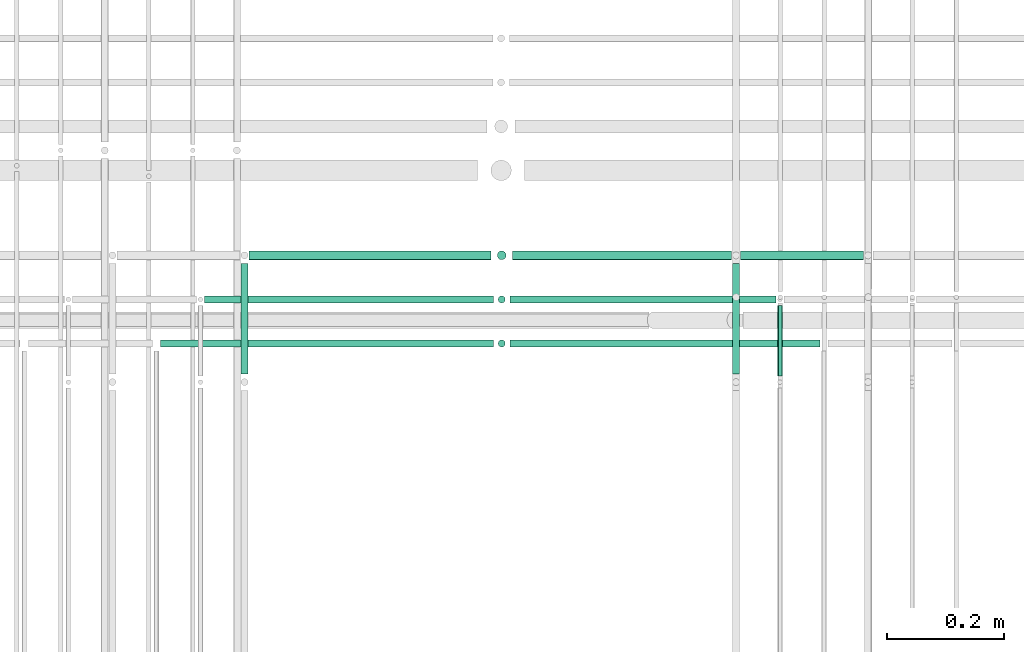
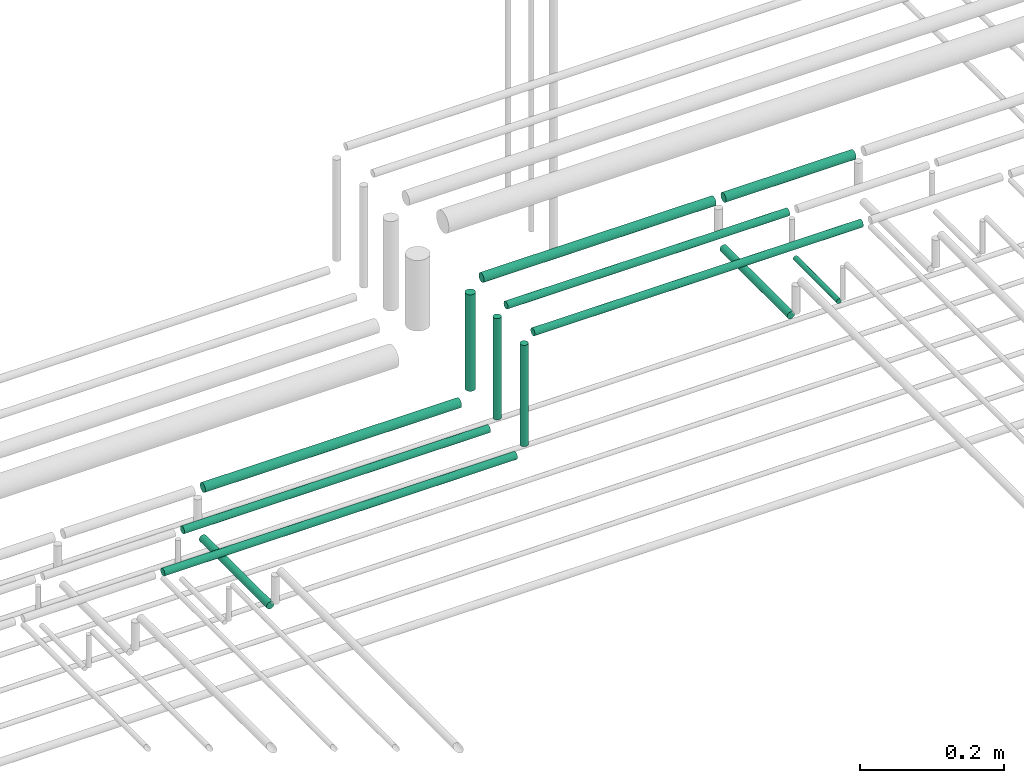
# One storey, part 152 of 331: 13 flow segments.
"""IFC2X3 building model written with IfcOpenShell, lengths in millimetres."""

from ifc_helpers import new_model, entity, si_unit, converted_unit, derived_unit, direction, frame, frame_2d, origin, origin_2d_with_axis, place, context, subcontext, project, spatial, circle, extrude, type_object, element, save


model = new_model("IFC2X3")

# Units and contexts
model_context = context("Model", 3, precision=0.01, world=origin(), true_north=direction((6.12303176911189e-17, 1.0)))
body_context = subcontext(model_context, "Body", "Model", "MODEL_VIEW")
ifc_project = project(units=[si_unit("LENGTHUNIT", "METRE", prefix="MILLI"), si_unit("AREAUNIT", "SQUARE_METRE"), si_unit("VOLUMEUNIT", "CUBIC_METRE"), converted_unit("PLANEANGLEUNIT", "DEGREE", entity("IfcRatioMeasure", 0.0174532925199433), si_unit("PLANEANGLEUNIT", "RADIAN"), dimensions=[0, 0, 0, 0, 0, 0, 0]), si_unit("MASSUNIT", "GRAM", prefix="KILO"), derived_unit("MASSDENSITYUNIT", [(si_unit("MASSUNIT", "GRAM", prefix="KILO"), 1), (si_unit("LENGTHUNIT", "METRE"), -3)]), derived_unit("MOMENTOFINERTIAUNIT", [(si_unit("LENGTHUNIT", "METRE"), 4)]), si_unit("TIMEUNIT", "SECOND"), si_unit("FREQUENCYUNIT", "HERTZ"), si_unit("THERMODYNAMICTEMPERATUREUNIT", "DEGREE_CELSIUS"), derived_unit("THERMALTRANSMITTANCEUNIT", [(si_unit("MASSUNIT", "GRAM", prefix="KILO"), 1), (si_unit("THERMODYNAMICTEMPERATUREUNIT", "KELVIN"), -1), (si_unit("TIMEUNIT", "SECOND"), -3)]), derived_unit("VOLUMETRICFLOWRATEUNIT", [(si_unit("LENGTHUNIT", "METRE"), 3), (si_unit("TIMEUNIT", "SECOND"), -1)]), derived_unit("MASSFLOWRATEUNIT", [(si_unit("MASSUNIT", "GRAM", prefix="KILO"), 1), (si_unit("TIMEUNIT", "SECOND"), -1)]), derived_unit("ROTATIONALFREQUENCYUNIT", [(si_unit("TIMEUNIT", "SECOND"), -1)]), si_unit("ELECTRICCURRENTUNIT", "AMPERE"), si_unit("ELECTRICVOLTAGEUNIT", "VOLT"), si_unit("POWERUNIT", "WATT"), si_unit("FORCEUNIT", "NEWTON", prefix="KILO"), si_unit("ILLUMINANCEUNIT", "LUX"), si_unit("LUMINOUSFLUXUNIT", "LUMEN"), si_unit("LUMINOUSINTENSITYUNIT", "CANDELA"), derived_unit("USERDEFINED", [(si_unit("MASSUNIT", "GRAM", prefix="KILO"), -1), (si_unit("LENGTHUNIT", "METRE"), -2), (si_unit("TIMEUNIT", "SECOND"), 3), (si_unit("LUMINOUSFLUXUNIT", "LUMEN"), 1)]), derived_unit("LINEARVELOCITYUNIT", [(si_unit("LENGTHUNIT", "METRE"), 1), (si_unit("TIMEUNIT", "SECOND"), -1)]), si_unit("PRESSUREUNIT", "PASCAL"), derived_unit("USERDEFINED", [(si_unit("LENGTHUNIT", "METRE"), -2), (si_unit("MASSUNIT", "GRAM", prefix="KILO"), 1), (si_unit("TIMEUNIT", "SECOND"), -2)]), derived_unit("LINEARFORCEUNIT", [(si_unit("MASSUNIT", "GRAM", prefix="KILO"), 1), (si_unit("LENGTHUNIT", "METRE"), 1), (si_unit("TIMEUNIT", "SECOND"), -2), (si_unit("LENGTHUNIT", "METRE"), -1)]), derived_unit("PLANARFORCEUNIT", [(si_unit("MASSUNIT", "GRAM", prefix="KILO"), 1), (si_unit("LENGTHUNIT", "METRE"), 1), (si_unit("TIMEUNIT", "SECOND"), -2), (si_unit("LENGTHUNIT", "METRE"), -2)])], contexts=[model_context])

# Site, building, storey
site_placement = place(None, frame((0.0, -0.00077364408347762, 0.0)))
site = spatial("IfcSite", under=ifc_project, at=site_placement, CompositionType="ELEMENT")
building_placement = place(site_placement, origin())
building = spatial("IfcBuilding", under=site, at=building_placement, CompositionType="ELEMENT")
storey_placement = place(building_placement, origin())
storey = spatial("IfcBuildingStorey", under=building, at=storey_placement, CompositionType="ELEMENT", Elevation=0.0)

# Flow segments
pipe_segment_type = type_object("IfcPipeSegmentType", PredefinedType="NOTDEFINED")
flow_segment_1_placement = place(storey_placement, frame((35465.5130615671, 8100.14924977613, 14669.4047277641)))
element("IfcFlowSegment", 1, at=flow_segment_1_placement, inside=storey, type_object=pipe_segment_type, context=body_context, shape_type="SweptSolid", body=[
    extrude(circle(Radius=4.0, at=origin_2d_with_axis()), frame((5.59527223591499, 0.0, 5.59527223591499), z_axis=(0.0, 1.0, 0.0), x_axis=(1.0, 0.0, 0.0)), (0.0, 0.0, 1.0), 120.860694073197),
])
flow_segment_2_placement = place(storey_placement, frame((35388.5130615671, 8104.14924977614, 14667.4047277641)))
element("IfcFlowSegment", 2, at=flow_segment_2_placement, inside=storey, type_object=pipe_segment_type, context=body_context, shape_type="SweptSolid", body=[
    extrude(circle(Radius=6.0, at=frame_2d((0.0, 2.16573425859679e-12), x_axis=(1.0, 0.0))), frame((7.59527223591454, 0.0, 7.59527223591887), z_axis=(0.0, 1.0, 0.0), x_axis=(1.0, 0.0, 0.0)), (0.0, 0.0, 1.0), 187.860694073183),
])
flow_segment_3_placement = place(storey_placement, frame((34551.5132627125, 8104.14924966515, 14467.404727873)))
element("IfcFlowSegment", 3, at=flow_segment_3_placement, inside=storey, type_object=pipe_segment_type, context=body_context, shape_type="SweptSolid", body=[
    extrude(circle(Radius=6.0, at=origin_2d_with_axis()), frame((7.59527223591454, 0.0, 7.5952722359167), z_axis=(0.0, 1.0, 0.0), x_axis=(1.0, 0.0, 0.0)), (0.0, 0.0, 1.0), 187.860694073193),
])
flow_segment_4_placement = place(storey_placement, frame((34416.1085349484, 8148.41467161337, 14542.404727764)))
element("IfcFlowSegment", 4, at=flow_segment_4_placement, inside=storey, type_object=pipe_segment_type, context=body_context, shape_type="SweptSolid", body=[
    extrude(circle(Radius=6.0, at=frame_2d((9.74580416368554e-12, 0.0), x_axis=(1.0, 0.0))), frame((0.0, 7.59527223592536, 7.5952722359167), z_axis=(1.0, 0.0, 0.0), x_axis=(0.0, 1.0, 0.0)), (0.0, 0.0, 1.0), 566.972016513596),
])
flow_segment_5_placement = place(storey_placement, frame((34491.1085388696, 8223.41467161341, 14542.4040101932)))
element("IfcFlowSegment", 5, at=flow_segment_5_placement, inside=storey, type_object=pipe_segment_type, context=body_context, shape_type="SweptSolid", body=[
    extrude(circle(Radius=6.0, at=frame_2d((1.08286712929839e-12, 0.0), x_axis=(1.0, 0.0))), frame((0.0, 7.5952722359167, 7.5952722359167), z_axis=(1.0, 0.0, 0.0), x_axis=(0.0, 1.0, 0.0)), (0.0, 0.0, 1.0), 491.972011372506),
])
flow_segment_6_placement = place(storey_placement, frame((35404.1083293895, 8296.91467161341, 14740.9047393113)))
element("IfcFlowSegment", 6, at=flow_segment_6_placement, inside=storey, type_object=pipe_segment_type, context=body_context, shape_type="SweptSolid", body=[
    extrude(circle(Radius=7.5, at=origin_2d_with_axis()), frame((0.0, 9.09527223591636, 9.09527223591636), z_axis=(1.0, 0.0, 0.0), x_axis=(0.0, 1.0, 0.0)), (0.0, 0.0, 1.0), 208.999989735819),
])
flow_segment_7_placement = place(storey_placement, frame((34567.1085305349, 8296.91467161341, 14540.9038469411)))
element("IfcFlowSegment", 7, at=flow_segment_7_placement, inside=storey, type_object=pipe_segment_type, context=body_context, shape_type="SweptSolid", body=[
    extrude(circle(Radius=7.5, at=origin_2d_with_axis()), frame((0.0, 9.09527223591636, 9.09527223591636), z_axis=(1.0, 0.0, 0.0), x_axis=(0.0, 1.0, 0.0)), (0.0, 0.0, 1.0), 411.972022774682),
])
flow_segment_8_placement = place(storey_placement, frame((35015.0805496145, 8296.91467161341, 14740.9047277641)))
element("IfcFlowSegment", 8, at=flow_segment_8_placement, inside=storey, type_object=pipe_segment_type, context=body_context, shape_type="SweptSolid", body=[
    extrude(circle(Radius=7.5, at=frame_2d((1.08286712929839e-12, 0.0), x_axis=(1.0, 0.0))), frame((0.0, 9.09527223591744, 9.09527223591636), z_axis=(1.0, 0.0, 0.0), x_axis=(0.0, 1.0, 0.0)), (0.0, 0.0, 1.0), 373.02777977503),
])
flow_segment_9_placement = place(storey_placement, frame((34987.9852792261, 8296.91467161341, 14567.9991201008)))
element("IfcFlowSegment", 9, at=flow_segment_9_placement, inside=storey, type_object=pipe_segment_type, context=body_context, shape_type="SweptSolid", body=[
    extrude(circle(Radius=7.5, at=origin_2d_with_axis()), frame((9.09527223591419, 9.09527223591636, 0.0), z_axis=(0.0, 0.0, 1.0), x_axis=(-1.0, 0.0, 0.0)), (0.0, 0.0, 1.0), 164.000879899222),
])
flow_segment_10_placement = place(storey_placement, frame((35011.0805526819, 8223.41467161341, 14742.4047282862)))
element("IfcFlowSegment", 10, at=flow_segment_10_placement, inside=storey, type_object=pipe_segment_type, context=body_context, shape_type="SweptSolid", body=[
    extrude(circle(Radius=6.0, at=frame_2d((-1.08286712929839e-12, 2.16573425859679e-12), x_axis=(1.0, 0.0))), frame((0.0, 7.5952722359167, 7.59527223591454), z_axis=(1.0, 0.0, 0.0), x_axis=(0.0, 1.0, 0.0)), (0.0, 0.0, 1.0), 453.027793756082),
])
flow_segment_11_placement = place(storey_placement, frame((34989.4852792261, 8223.41467161342, 14563.9992818191)))
element("IfcFlowSegment", 11, at=flow_segment_11_placement, inside=storey, type_object=pipe_segment_type, context=body_context, shape_type="SweptSolid", body=[
    extrude(circle(Radius=6.0, at=origin_2d_with_axis()), frame((7.59527223591454, 7.59527223591562, 0.0), z_axis=(0.0, 0.0, 1.0), x_axis=(-1.0, 0.0, 0.0)), (0.0, 0.0, 1.0), 172.000735594653),
])
flow_segment_12_placement = place(storey_placement, frame((35011.080551462, 8148.41467161338, 14742.4047277641)))
element("IfcFlowSegment", 12, at=flow_segment_12_placement, inside=storey, type_object=pipe_segment_type, context=body_context, shape_type="SweptSolid", body=[
    extrude(circle(Radius=6.0, at=frame_2d((-1.08286712929839e-12, 0.0), x_axis=(1.0, 0.0))), frame((0.0, 7.59527223591778, 7.5952722359167), z_axis=(1.0, 0.0, 0.0), x_axis=(0.0, 1.0, 0.0)), (0.0, 0.0, 1.0), 528.027782341026),
])
flow_segment_13_placement = place(storey_placement, frame((34989.4852792261, 8148.41467161339, 14564.0)))
element("IfcFlowSegment", 13, at=flow_segment_13_placement, inside=storey, type_object=pipe_segment_type, context=body_context, shape_type="SweptSolid", body=[
    extrude(circle(Radius=6.0, at=origin_2d_with_axis()), frame((7.59527223591454, 7.59527223591562, 0.0), z_axis=(0.0, 0.0, 1.0), x_axis=(-1.0, 0.0, 0.0)), (0.0, 0.0, 1.0), 172.000000000041),
])

save(model, "model.ifc")
